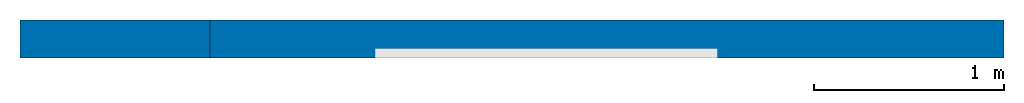
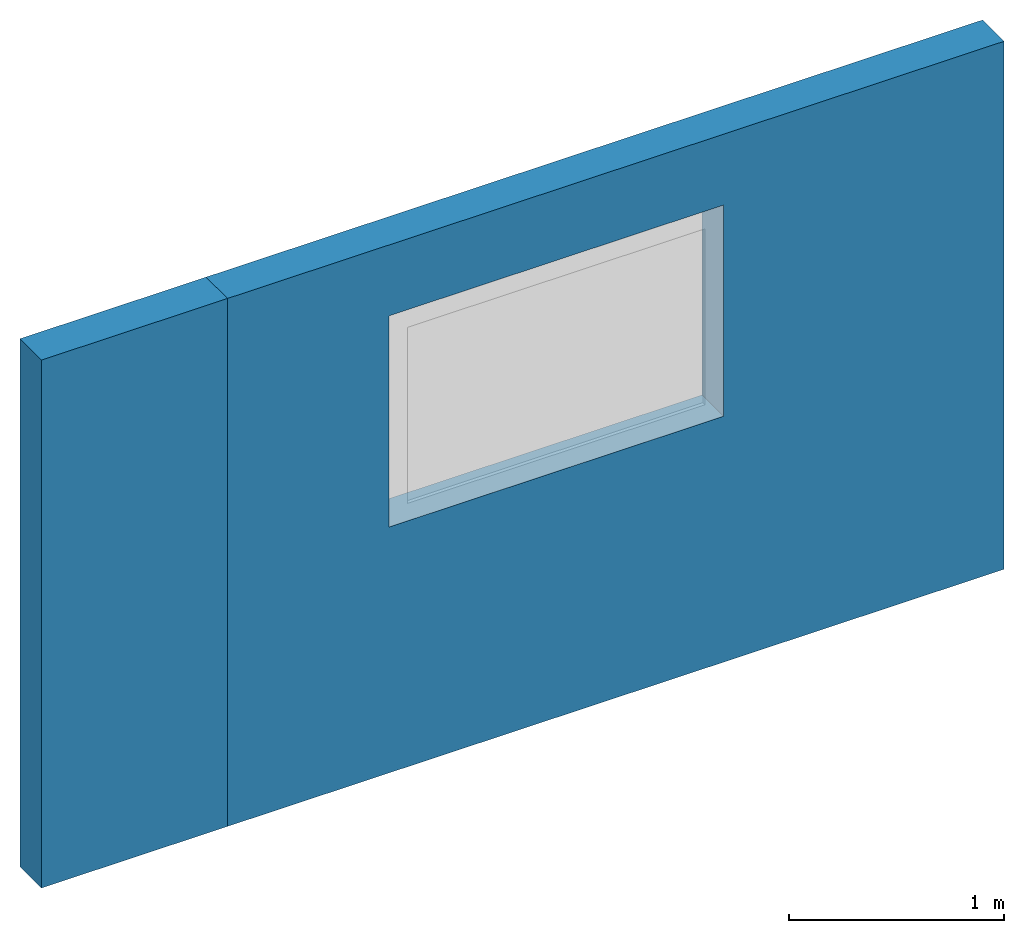
# One storey, part 1 of 2: 2 walls, 1 opening.
"""IFC4 building model written with IfcOpenShell, lengths in millimetres."""

import ifcopenshell
import ifcopenshell.guid

model = None  # the IFC model being written
_history = None  # IfcOwnerHistory: only IFC2X3 demands one
_inside = {}  # id of a spatial element -> (the spatial element, [elements in it])
_under = {}  # id of a project, library or spatial element -> (it, [spatial elements below it])
_declared = {}  # id of a project -> (the project, [libraries it declares])
_typed = {}  # id of a type object -> (the type object, [elements of that type])
_made_of = {}  # id of a material, layer set ... -> (it, [elements and type objects made of it])


def new_model(schema):
    """Start an empty IFC model of exactly this schema.

    Asked for "IFC4X3", IfcOpenShell would pick the latest addendum, in which some entities
    have other attributes; the version numbers below select the first issue.
    IFC2X3 requires an IfcOwnerHistory on every rooted entity: one is made here for all.
    """
    global model, _history
    if schema == "IFC4X3":
        model = ifcopenshell.file(schema_version=(4, 3, 0, 0))
    else:
        model = ifcopenshell.file(schema=schema)
    _inside.clear()
    _under.clear()
    _declared.clear()
    _typed.clear()
    _made_of.clear()
    _history = None
    if model.schema == "IFC2X3":
        org = make("IfcOrganization", Name="unknown")
        user = make(
            "IfcPersonAndOrganization",
            ThePerson=make("IfcPerson", FamilyName="unknown"),
            TheOrganization=org,
        )
        app = make(
            "IfcApplication",
            ApplicationDeveloper=org,
            Version="unknown",
            ApplicationFullName="unknown",
            ApplicationIdentifier="unknown",
        )
        _history = make(
            "IfcOwnerHistory",
            OwningUser=user,
            OwningApplication=app,
            ChangeAction="ADDED",
            CreationDate=0,
        )
    return model


def make(cls, **values):
    """One entity of the class cls with the attributes given. An attribute that is None is left unset."""
    return model.create_entity(
        cls, **{name: value for name, value in values.items() if value is not None}
    )


def entity(cls, *values):
    """Any entity or typed value of the class cls, its attributes in the order of the schema. None: left unset."""
    e = model.create_entity(cls)
    for i, value in enumerate(values):
        if value is not None:
            e[i] = value
    return e


def rooted(cls, **values):
    """An entity with a GlobalId (a new one), such as an element, a storey or a relation."""
    return make(cls, GlobalId=ifcopenshell.guid.new(), OwnerHistory=_history, **values)


def si_unit(unit_type, name, prefix=None):
    """IfcSIUnit, for example si_unit("LENGTHUNIT", "METRE", prefix="MILLI")."""
    return make("IfcSIUnit", UnitType=unit_type, Prefix=prefix, Name=name)


def converted_unit(unit_type, name, factor, base, dimensions=None, offset=None):
    """IfcConversionBasedUnit, such as the inch: factor (a typed value) times the base unit."""
    return make(
        "IfcConversionBasedUnit"
        if offset is None
        else "IfcConversionBasedUnitWithOffset",
        ConversionOffset=offset,
        Dimensions=None
        if dimensions is None
        else entity("IfcDimensionalExponents", *dimensions),
        UnitType=unit_type,
        Name=name,
        ConversionFactor=make(
            "IfcMeasureWithUnit", ValueComponent=factor, UnitComponent=base
        ),
    )


def assignment(units):
    """IfcUnitAssignment: the units of a project."""
    return None if units is None else make("IfcUnitAssignment", Units=units)


def point(xyz):
    """IfcCartesianPoint."""
    return None if xyz is None else make("IfcCartesianPoint", Coordinates=xyz)


def direction(xyz):
    """IfcDirection."""
    return None if xyz is None else make("IfcDirection", DirectionRatios=xyz)


def frame(location, z_axis=None, x_axis=None):
    """IfcAxis2Placement3D, a coordinate frame: its origin and axes. An axis left out is left unset."""
    return make(
        "IfcAxis2Placement3D",
        Location=point(location),
        Axis=direction(z_axis),
        RefDirection=direction(x_axis),
    )


def frame_2d(location, x_axis=None):
    """IfcAxis2Placement2D, a coordinate frame in the plane: its origin and x axis."""
    return make(
        "IfcAxis2Placement2D", Location=point(location), RefDirection=direction(x_axis)
    )


def origin_with_axes():
    """The frame at (0, 0, 0) with the z axis (0, 0, 1) and the x axis (1, 0, 0) written out."""
    return frame((0.0, 0.0, 0.0), z_axis=(0.0, 0.0, 1.0), x_axis=(1.0, 0.0, 0.0))


def place(relative_to, where):
    """IfcLocalPlacement: puts the frame where relative to a parent placement (None: the world)."""
    return make(
        "IfcLocalPlacement", PlacementRelTo=relative_to, RelativePlacement=where
    )


def context(
    kind, dimensions, precision=None, world=None, true_north=None, identifier=None
):
    """IfcGeometricRepresentationContext, for example the 3D "Model" context."""
    return make(
        "IfcGeometricRepresentationContext",
        ContextIdentifier=identifier,
        ContextType=kind,
        CoordinateSpaceDimension=dimensions,
        Precision=precision,
        WorldCoordinateSystem=world,
        TrueNorth=true_north,
    )


def subcontext(parent, identifier, kind, view, scale=None):
    """IfcGeometricRepresentationSubContext, for example "Body" below "Model"."""
    return make(
        "IfcGeometricRepresentationSubContext",
        ContextIdentifier=identifier,
        ContextType=kind,
        ParentContext=parent,
        TargetScale=scale,
        TargetView=view,
    )


def project(units=None, contexts=None):
    """IfcProject with its units and contexts."""
    return rooted(
        "IfcProject",
        Name="project",
        RepresentationContexts=contexts,
        UnitsInContext=assignment(units),
    )


def spatial(cls, under=None, at=None, **own):
    """A site, building, storey or space (cls), placed at a placement, below another one or the project."""
    s = rooted(cls, ObjectPlacement=at, **own)
    if under is not None:
        _under.setdefault(under.id(), (under, []))[1].append(s)
    return s


def polyline(points):
    """IfcPolyline through the points."""
    return make("IfcPolyline", Points=[point(p) for p in points])


def point_list(points):
    """IfcCartesianPointList2D or 3D."""
    cls = (
        "IfcCartesianPointList2D" if len(points[0]) == 2 else "IfcCartesianPointList3D"
    )
    return make(cls, CoordList=points)


def outline(outer, holes=None, kind="AREA"):
    """IfcArbitraryClosedProfileDef: a profile drawn as a closed curve; with holes, ...WithVoids."""
    if holes is None:
        return make("IfcArbitraryClosedProfileDef", ProfileType=kind, OuterCurve=outer)
    return make(
        "IfcArbitraryProfileDefWithVoids",
        ProfileType=kind,
        OuterCurve=outer,
        InnerCurves=holes,
    )


def extrude(swept, where, along, depth):
    """IfcExtrudedAreaSolid: the profile swept, set in the frame where, extruded along a direction by depth."""
    return make(
        "IfcExtrudedAreaSolid",
        SweptArea=swept,
        Position=where,
        ExtrudedDirection=direction(along),
        Depth=depth,
    )


def polygons(points, faces, closed=None, point_numbers=None):
    """IfcPolygonalFaceSet: a face is its outer loop, then its inner loops; points numbered from 1."""
    made = []
    for loops in faces:
        if len(loops) == 1:
            made.append(make("IfcIndexedPolygonalFace", CoordIndex=loops[0]))
        else:
            made.append(
                make(
                    "IfcIndexedPolygonalFaceWithVoids",
                    CoordIndex=loops[0],
                    InnerCoordIndices=loops[1:],
                )
            )
    return make(
        "IfcPolygonalFaceSet",
        Coordinates=point_list(points),
        Closed=closed,
        Faces=made,
        PnIndex=point_numbers,
    )


def shape(context_of_items, identifier, shape_type, items):
    """IfcShapeRepresentation: the items that make up one representation, for example the "Body"."""
    return make(
        "IfcShapeRepresentation",
        ContextOfItems=context_of_items,
        RepresentationIdentifier=identifier,
        RepresentationType=shape_type,
        Items=items,
    )


def material(Name=None, Category=None):
    """IfcMaterial."""
    return make("IfcMaterial", Name=Name, Category=Category)


def layer(
    of_material, thickness, ventilated=None, Name=None, Category=None, Priority=None
):
    """IfcMaterialLayer: one layer of a wall or slab, of a material (None: an air gap)."""
    return make(
        "IfcMaterialLayer",
        Material=of_material,
        LayerThickness=thickness,
        IsVentilated=ventilated,
        Name=Name,
        Category=Category,
        Priority=Priority,
    )


def layer_set(layers, Name=None):
    """IfcMaterialLayerSet."""
    return make("IfcMaterialLayerSet", MaterialLayers=layers, LayerSetName=Name)


def layer_usage(for_layer_set, set_direction, sense, offset, extent=None):
    """IfcMaterialLayerSetUsage: how a layer set lies in its element."""
    return make(
        "IfcMaterialLayerSetUsage",
        ForLayerSet=for_layer_set,
        LayerSetDirection=set_direction,
        DirectionSense=sense,
        OffsetFromReferenceLine=offset,
        ReferenceExtent=extent,
    )


def made_of(thing, what):
    """Note that an element or type object is made of a material, layer set ...; save() writes the relation."""
    if what is not None:
        _made_of.setdefault(what.id(), (what, []))[1].append(thing)
    return thing


def type_object(cls, material=None, **own):
    """A type object (cls), such as IfcWallType, which elements share."""
    return made_of(rooted(cls, **own), material)


def element(
    cls,
    number,
    at=None,
    inside=None,
    cuts=None,
    type_object=None,
    material=None,
    context=None,
    identifier="Body",
    shape_type=None,
    held_by="IfcProductDefinitionShape",
    body=None,
    shapes=None,
    **own,
):
    """One element of the class cls, such as IfcWall. Its Tag is "e" and its number.

    at: its placement. inside: the storey or other place that contains it. cuts: it is an
    opening in that element (IfcRelVoidsElement). A single representation is given by context,
    identifier, shape_type and body (its items); several are given by shapes. held_by: the class
    of the entity that holds the representations. save() writes the other relations.
    """
    e = rooted(cls, Tag="e%d" % number, ObjectPlacement=at, **own)
    if body is not None:
        shapes = [shape(context, identifier, shape_type, body)]
    if shapes is not None:
        e.Representation = make(held_by, Representations=shapes)
    if inside is not None:
        _inside.setdefault(inside.id(), (inside, []))[1].append(e)
    if cuts is not None:
        rooted(
            "IfcRelVoidsElement", RelatingBuildingElement=cuts, RelatedOpeningElement=e
        )
    if type_object is not None:
        _typed.setdefault(type_object.id(), (type_object, []))[1].append(e)
    return made_of(e, material)


def aggregate(whole, parts):
    """IfcRelAggregates: a whole, such as a stair, and the parts it consists of."""
    return rooted("IfcRelAggregates", RelatingObject=whole, RelatedObjects=parts)


def save(model, path):
    """Write the relations noted so far, then the file.

    IfcRelAggregates (storeys below a building ...), IfcRelContainedInSpatialStructure (elements
    in a storey), IfcRelDefinesByType, IfcRelAssociatesMaterial and IfcRelDeclares: one each for
    every whole, place, type object, material and project.
    """
    for whole, parts in _under.values():
        aggregate(whole, parts)
    for where, things in _inside.values():
        rooted(
            "IfcRelContainedInSpatialStructure",
            RelatedElements=things,
            RelatingStructure=where,
        )
    for kind, things in _typed.values():
        rooted("IfcRelDefinesByType", RelatedObjects=things, RelatingType=kind)
    for what, things in _made_of.values():
        rooted("IfcRelAssociatesMaterial", RelatedObjects=things, RelatingMaterial=what)
    for by, libraries in _declared.values():
        rooted("IfcRelDeclares", RelatingContext=by, RelatedDefinitions=libraries)
    model.write(path)


model = new_model("IFC4")

# Units and contexts
model_context = context("Model", 3, precision=1e-05, world=origin_with_axes())
plan_context = context("Plan", 2, precision=1e-05, world=frame_2d((0.0, 0.0, 0.0), x_axis=(1.0, 0.0, 0.0)))
body_context = subcontext(model_context, "Body", "Model", "MODEL_VIEW")
ifc_project = project(units=[si_unit("VOLUMEUNIT", "CUBIC_METRE", prefix="MILLI"), si_unit("LENGTHUNIT", "METRE", prefix="MILLI"), converted_unit("PLANEANGLEUNIT", "degree", entity("IfcReal", 0.0174532925199433), si_unit("PLANEANGLEUNIT", "RADIAN"), dimensions=[0, 0, 0, 0, 0, 0, 0]), si_unit("AREAUNIT", "SQUARE_METRE", prefix="MILLI")], contexts=[model_context, plan_context])

# Site, building, storey
site_placement = place(None, origin_with_axes())
site = spatial("IfcSite", under=ifc_project, at=site_placement)
building_placement = place(site_placement, origin_with_axes())
building = spatial("IfcBuilding", under=site, at=building_placement, Name="Building")
storey_placement = place(building_placement, origin_with_axes())
storey = spatial("IfcBuildingStorey", under=building, at=storey_placement, Name="Storey")

# Wall
ifc_material = material()
ifc_layer = layer(ifc_material, 200.0)
ifc_layer_set = layer_set([ifc_layer])
ifc_layer_usage_1 = layer_usage(ifc_layer_set, "AXIS2", "POSITIVE", 0.0)
wall_type = type_object("IfcWallType", Name="DEMO200", material=ifc_layer_set)
wall_1_placement = place(storey_placement, origin_with_axes())
element("IfcWall", 1, at=wall_1_placement, inside=storey, type_object=wall_type, material=ifc_layer_usage_1, Name="Wall", context=body_context, shape_type="SweptSolid", body=[
    extrude(outline(polyline([(-100.000001490116, -500.0), (100.000001490116, -500.0), (100.000001490116, 500.0), (-100.000001490116, 500.0), (-100.000001490116, -500.0)])), frame((500.0, 100.000001490116, 0.0), z_axis=(0.0, 0.0, -1.0), x_axis=(0.0, -1.0, 0.0)), (0.0, 0.0, -1.0), 3000.0),
])

# Wall, opening
ifc_layer_usage_2 = layer_usage(ifc_layer_set, "AXIS2", "POSITIVE", 0.0)
wall_2_placement = place(storey_placement, origin_with_axes())
wall_2 = element("IfcWall", 2, at=wall_2_placement, inside=storey, type_object=wall_type, material=ifc_layer_usage_2, Name="Wall", context=body_context, shape_type="SweptSolid", body=[
    extrude(outline(polyline([(-100.000001490116, -2586.58933639526), (100.000001490116, -2586.58933639526), (100.000001490116, 2586.58933639526), (-100.000001490116, 2586.58933639526), (-100.000001490116, -2586.58933639526)])), frame((2586.58933639526, 100.000001490116, 0.0), z_axis=(0.0, 0.0, -1.0), x_axis=(0.0, -1.0, 0.0)), (0.0, 0.0, -1.0), 3000.0),
])
opening_placement = place(wall_2_placement, frame((1866.46378040314, 0.0, 1397.2282409668), z_axis=(0.0, 0.0, 1.0), x_axis=(1.0, 0.0, 0.0)))
element("IfcOpeningElement", 3, at=opening_placement, cuts=wall_2, Name="Opening", context=body_context, shape_type="Tessellation", body=[
    polygons([(0.0, -99.9999923706055, 0.0), (0.0, -99.9999923706055, 1200.0), (0.0, 300.0, 0.0), (0.0, 300.0, 1200.0), (1799.99963378906, -99.9999923706055, 0.0), (1799.99963378906, -99.9999923706055, 1200.0), (1799.99963378906, 300.0, 0.0), (1799.99963378906, 300.0, 1200.0)], [[[1, 2, 4, 3]], [[3, 4, 8, 7]], [[7, 8, 6, 5]], [[5, 6, 2, 1]], [[3, 7, 5, 1]], [[8, 4, 2, 6]]]),
])

save(model, "model.ifc")
